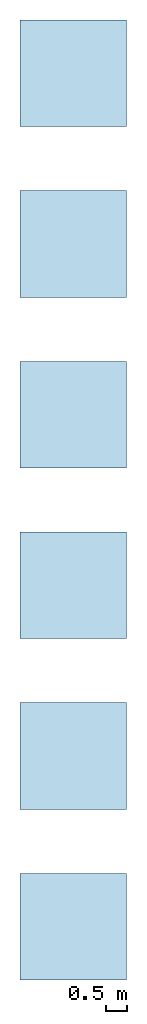
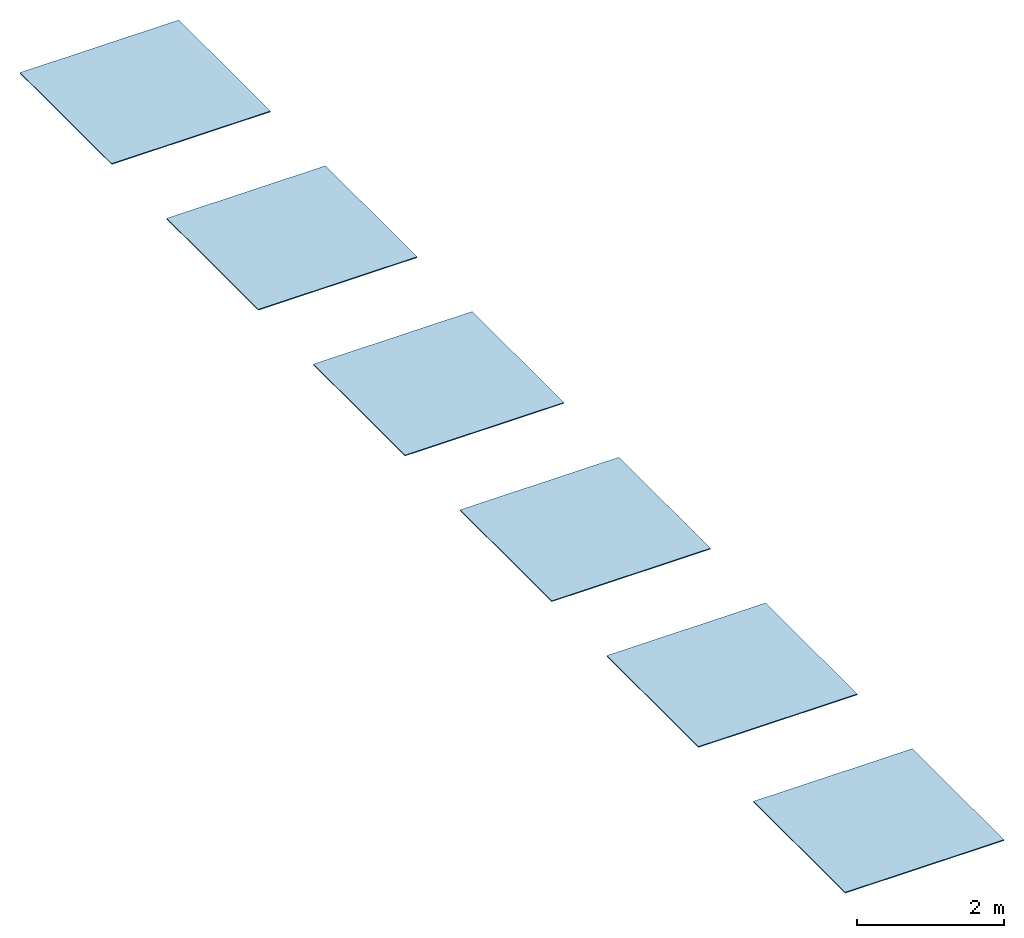
# One storey: 6 slabs, 6 elements without a shape of their own.
"""IFC2X3 building model written with IfcOpenShell, lengths in millimetres."""

from ifc_helpers import new_model, entity, si_unit, converted_unit, derived_unit, direction, frame, frame_2d, origin, place, context, subcontext, project, spatial, rectangle, extrude, material, layer, layer_set, element, aggregate, save


model = new_model("IFC2X3")

# Units and contexts
model_context = context("Model", 3, precision=0.01, world=origin(), true_north=direction((6.12303176911189e-17, 1.0)))
body_context = subcontext(model_context, "Body", "Model", "MODEL_VIEW")
ifc_project = project(units=[si_unit("LENGTHUNIT", "METRE", prefix="MILLI"), si_unit("AREAUNIT", "SQUARE_METRE"), si_unit("VOLUMEUNIT", "CUBIC_METRE"), converted_unit("PLANEANGLEUNIT", "DEGREE", entity("IfcRatioMeasure", 0.0174532925199433), si_unit("PLANEANGLEUNIT", "RADIAN"), dimensions=[0, 0, 0, 0, 0, 0, 0]), si_unit("MASSUNIT", "GRAM", prefix="KILO"), derived_unit("MASSDENSITYUNIT", [(si_unit("MASSUNIT", "GRAM", prefix="KILO"), 1), (si_unit("LENGTHUNIT", "METRE"), -3)]), si_unit("TIMEUNIT", "SECOND"), si_unit("FREQUENCYUNIT", "HERTZ"), si_unit("THERMODYNAMICTEMPERATUREUNIT", "DEGREE_CELSIUS"), derived_unit("THERMALTRANSMITTANCEUNIT", [(si_unit("MASSUNIT", "GRAM", prefix="KILO"), 1), (si_unit("THERMODYNAMICTEMPERATUREUNIT", "KELVIN"), -1), (si_unit("TIMEUNIT", "SECOND"), -3)]), derived_unit("VOLUMETRICFLOWRATEUNIT", [(si_unit("LENGTHUNIT", "METRE"), 3), (si_unit("TIMEUNIT", "SECOND"), -1)]), si_unit("ELECTRICCURRENTUNIT", "AMPERE"), si_unit("ELECTRICVOLTAGEUNIT", "VOLT"), si_unit("POWERUNIT", "WATT"), si_unit("FORCEUNIT", "NEWTON", prefix="KILO"), si_unit("ILLUMINANCEUNIT", "LUX"), si_unit("LUMINOUSFLUXUNIT", "LUMEN"), si_unit("LUMINOUSINTENSITYUNIT", "CANDELA"), derived_unit("USERDEFINED", [(si_unit("MASSUNIT", "GRAM", prefix="KILO"), -1), (si_unit("LENGTHUNIT", "METRE"), -2), (si_unit("TIMEUNIT", "SECOND"), 3), (si_unit("LUMINOUSFLUXUNIT", "LUMEN"), 1)]), derived_unit("LINEARVELOCITYUNIT", [(si_unit("LENGTHUNIT", "METRE"), 1), (si_unit("TIMEUNIT", "SECOND"), -1)]), si_unit("PRESSUREUNIT", "PASCAL"), derived_unit("USERDEFINED", [(si_unit("LENGTHUNIT", "METRE"), -2), (si_unit("MASSUNIT", "GRAM", prefix="KILO"), 1), (si_unit("TIMEUNIT", "SECOND"), -2)])], contexts=[model_context])

# Site, building, storey
site_placement = place(None, origin())
site = spatial("IfcSite", under=ifc_project, at=site_placement, CompositionType="ELEMENT")
building_placement = place(site_placement, origin())
building = spatial("IfcBuilding", under=site, at=building_placement, CompositionType="ELEMENT")
storey_placement = place(building_placement, origin())
storey = spatial("IfcBuildingStorey", under=building, at=storey_placement, Name="Level 0", CompositionType="ELEMENT", Elevation=0.0)

# Roof, slab
roof_1_placement = place(storey_placement, origin())
roof_1 = element("IfcRoof", 1, at=roof_1_placement, inside=storey, ShapeType="NOTDEFINED")
ifc_material_1 = material()
ifc_layer_1 = layer(ifc_material_1, 16.0)
ifc_layer_set_1 = layer_set([ifc_layer_1])
slab_1_placement = place(storey_placement, origin())
slab_1 = element("IfcSlab", 2, at=slab_1_placement, material=ifc_layer_set_1, PredefinedType="ROOF", context=body_context, shape_type="SweptSolid", body=[
    extrude(rectangle(XDim=2500.0, YDim=2500.0, at=frame_2d((0.0, 0.0), x_axis=(0.0, 1.0))), frame((1250.0, -1250.0, 0.0)), (0.0, 0.0, 1.0), 16.0),
])
aggregate(roof_1, [slab_1])

roof_2_placement = place(storey_placement, frame((0.0, -6500.0, 0.0)))
roof_2 = element("IfcRoof", 3, at=roof_2_placement, inside=storey, ShapeType="NOTDEFINED")
ifc_material_2 = material()
ifc_layer_2 = layer(ifc_material_2, 16.0)
ifc_layer_set_2 = layer_set([ifc_layer_2])
slab_2_placement = place(roof_2_placement, origin())
slab_2 = element("IfcSlab", 4, at=slab_2_placement, material=ifc_layer_set_2, PredefinedType="ROOF", context=body_context, shape_type="SweptSolid", body=[
    extrude(rectangle(XDim=2500.0, YDim=2500.0, at=frame_2d((0.0, -5.6843418860808e-13), x_axis=(0.0, 1.0))), frame((1250.0, 1250.0, 0.0)), (0.0, 0.0, 1.0), 16.0),
])
aggregate(roof_2, [slab_2])

roof_3_placement = place(storey_placement, frame((0.0, -10500.0, 0.0)))
roof_3 = element("IfcRoof", 5, at=roof_3_placement, inside=storey, ShapeType="NOTDEFINED")
ifc_material_3 = material()
ifc_layer_3 = layer(ifc_material_3, 16.0)
ifc_layer_set_3 = layer_set([ifc_layer_3])
slab_3_placement = place(roof_3_placement, origin())
slab_3 = element("IfcSlab", 6, at=slab_3_placement, material=ifc_layer_set_3, PredefinedType="ROOF", context=body_context, shape_type="SweptSolid", body=[
    extrude(rectangle(XDim=2500.0, YDim=2500.0, at=frame_2d((0.0, 0.0), x_axis=(0.0, 1.0))), frame((1250.0, 1250.0, 0.0)), (0.0, 0.0, 1.0), 16.0),
])
aggregate(roof_3, [slab_3])

roof_4_placement = place(storey_placement, frame((0.0, -14500.0, 0.0)))
roof_4 = element("IfcRoof", 7, at=roof_4_placement, inside=storey, ShapeType="NOTDEFINED")
ifc_material_4 = material()
ifc_layer_4 = layer(ifc_material_4, 16.0)
ifc_layer_set_4 = layer_set([ifc_layer_4])
slab_4_placement = place(roof_4_placement, origin())
slab_4 = element("IfcSlab", 8, at=slab_4_placement, material=ifc_layer_set_4, PredefinedType="ROOF", context=body_context, shape_type="SweptSolid", body=[
    extrude(rectangle(XDim=2500.0, YDim=2500.0, at=frame_2d((0.0, 0.0), x_axis=(0.0, 1.0))), frame((1250.0, 1250.0, 0.0)), (0.0, 0.0, 1.0), 16.0),
])
aggregate(roof_4, [slab_4])

roof_5_placement = place(storey_placement, frame((0.0, -18500.0, 0.0)))
roof_5 = element("IfcRoof", 9, at=roof_5_placement, inside=storey, ShapeType="NOTDEFINED")
ifc_material_5 = material()
ifc_layer_5 = layer(ifc_material_5, 16.0)
ifc_layer_set_5 = layer_set([ifc_layer_5])
slab_5_placement = place(roof_5_placement, origin())
slab_5 = element("IfcSlab", 10, at=slab_5_placement, material=ifc_layer_set_5, PredefinedType="ROOF", context=body_context, shape_type="SweptSolid", body=[
    extrude(rectangle(XDim=2500.0, YDim=2500.0, at=frame_2d((0.0, 0.0), x_axis=(0.0, 1.0))), frame((1250.0, 1250.0, 0.0)), (0.0, 0.0, 1.0), 16.0),
])
aggregate(roof_5, [slab_5])

roof_6_placement = place(storey_placement, frame((0.0, -22500.0, 0.0)))
roof_6 = element("IfcRoof", 11, at=roof_6_placement, inside=storey, ShapeType="NOTDEFINED")
ifc_material_6 = material()
ifc_layer_6 = layer(ifc_material_6, 16.0)
ifc_layer_set_6 = layer_set([ifc_layer_6])
slab_6_placement = place(roof_6_placement, origin())
slab_6 = element("IfcSlab", 12, at=slab_6_placement, material=ifc_layer_set_6, PredefinedType="ROOF", context=body_context, shape_type="SweptSolid", body=[
    extrude(rectangle(XDim=2500.0, YDim=2500.0, at=frame_2d((0.0, 2.27373675443232e-12), x_axis=(0.0, 1.0))), frame((1250.0, 1250.0, 0.0)), (0.0, 0.0, 1.0), 16.0),
])
aggregate(roof_6, [slab_6])

save(model, "model.ifc")
